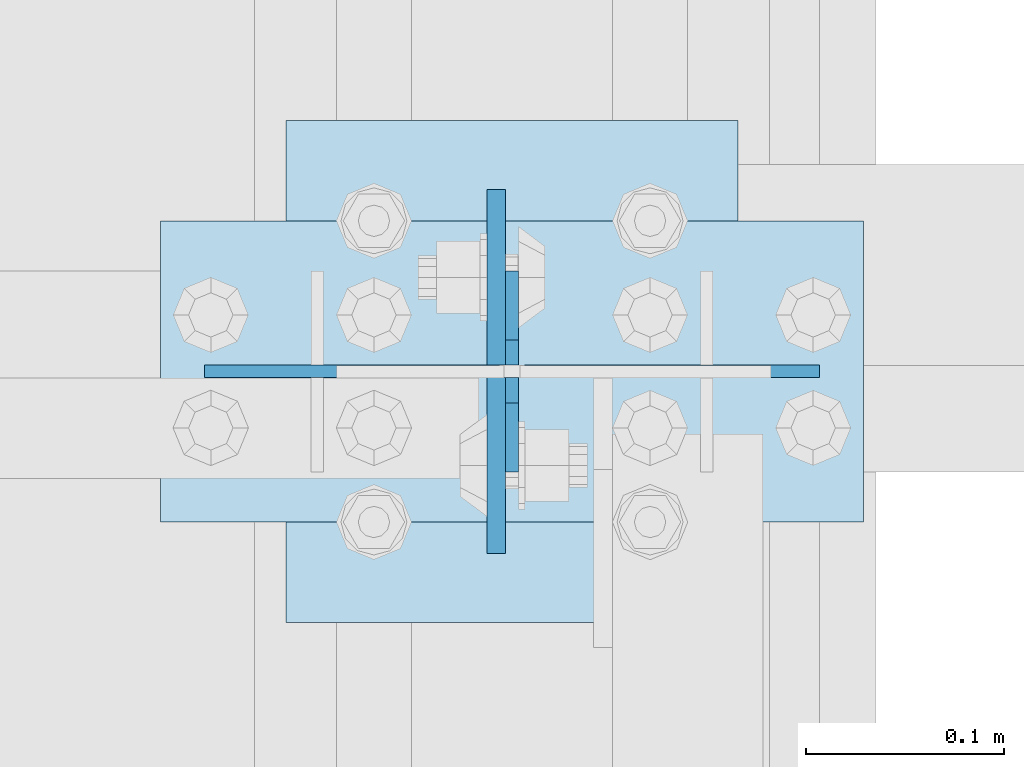
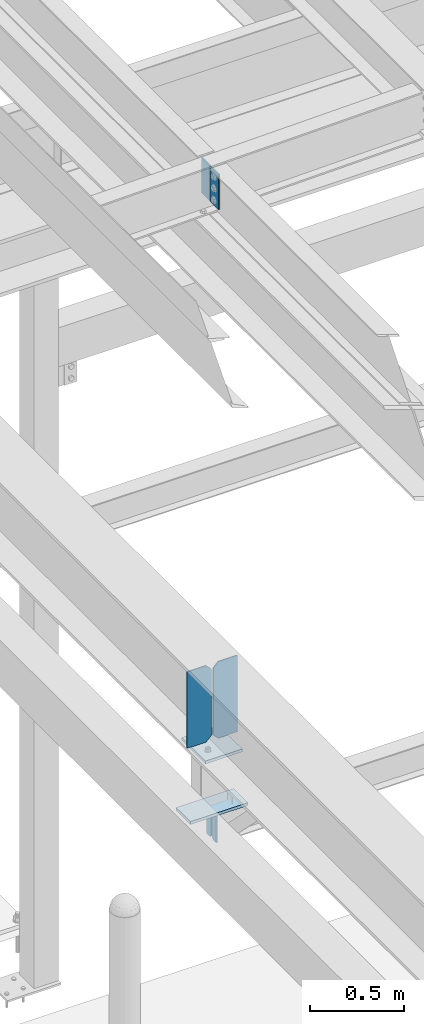
# One storey, part 3387 of 3843: 8 plates, 4 elements without a shape of their own.
"""IFC2X3 building model written with IfcOpenShell, lengths in millimetres."""

from ifc_helpers import new_model, si_unit, frame, origin_with_axes, place, context, subcontext, project, spatial, faceted_brep, material, type_object, element, aggregate, save


model = new_model("IFC2X3")

# Units and contexts
model_context = context("Model", 3, precision=1e-05, world=origin_with_axes())
body_context = subcontext(model_context, "Body", "Model", "MODEL_VIEW")
ifc_project = project(units=[si_unit("LENGTHUNIT", "METRE", prefix="MILLI"), si_unit("AREAUNIT", "SQUARE_METRE"), si_unit("VOLUMEUNIT", "CUBIC_METRE"), si_unit("MASSUNIT", "GRAM", prefix="KILO"), si_unit("TIMEUNIT", "SECOND"), si_unit("PLANEANGLEUNIT", "RADIAN"), si_unit("SOLIDANGLEUNIT", "STERADIAN"), si_unit("THERMODYNAMICTEMPERATUREUNIT", "DEGREE_CELSIUS"), si_unit("LUMINOUSINTENSITYUNIT", "LUMEN")], contexts=[model_context])

# Site, building, storey
site_placement = place(None, origin_with_axes())
site = spatial("IfcSite", under=ifc_project, at=site_placement, CompositionType="ELEMENT")
building_placement = place(site_placement, origin_with_axes())
building = spatial("IfcBuilding", under=site, at=building_placement, Name="Undefined", CompositionType="ELEMENT")
storey_placement = place(building_placement, origin_with_axes())
storey = spatial("IfcBuildingStorey", under=building, at=storey_placement, Name="Undefined", CompositionType="ELEMENT", Elevation=0.0)

# Assembly, plates
assembly_1_placement = place(storey_placement, origin_with_axes())
assembly_1 = element("IfcElementAssembly", 1, at=assembly_1_placement, inside=storey, Name="BEAM", AssemblyPlace="NOTDEFINED", PredefinedType="RIGID_FRAME")
ifc_material = material(Name="STEEL/A572-50")
plate_type_1 = type_object("IfcPlateType", PredefinedType="NOTDEFINED")
plate_1_placement = place(assembly_1_placement, frame((36568.0624999856, 79803.6249999999, 45691.4946293709), z_axis=(0.0, -1.0, 0.0), x_axis=(0.0, 0.0, -1.0)))
plate_1 = element("IfcPlate", 2, at=plate_1_placement, type_object=plate_type_1, material=ifc_material, Name="PLATE", context=body_context, shape_type="Brep", body=[
    faceted_brep([(0.0, -4.76249999999709, 0.0), (0.0, -4.76249999999709, 88.9000015258789), (0.0, 4.76249999999709, 88.9000015258789), (0.0, 4.76249999999709, 0.0), (228.600006102781, -4.7625000004191, 88.9000015257589), (228.600006102781, 4.76249999954598, 88.9000015257443), (228.600006103079, -4.7625000004482, 7.27595761418343e-12), (228.600006103079, 4.76249999954598, -7.27595761418343e-12)], [[[0, 1, 2, 3]], [[1, 4, 5, 2]], [[4, 6, 7, 5]], [[6, 0, 3, 7]], [[5, 7, 3, 2]], [[6, 4, 1, 0]]]),
])
plate_2_placement = place(assembly_1_placement, frame((36568.0624999913, 79809.9749999999, 45691.494629371), z_axis=(0.0, 1.0, 0.0), x_axis=(0.0, 0.0, -1.0)))
plate_2 = element("IfcPlate", 3, at=plate_2_placement, type_object=plate_type_1, material=ifc_material, Name="PLATE", context=body_context, shape_type="Brep", body=[
    faceted_brep([(0.0, -4.76249999999709, 0.0), (0.0, -4.76249999999709, 88.9000015258789), (0.0, 4.76249999999709, 88.9000015258789), (0.0, 4.76249999999709, 0.0), (228.600006102781, -4.7625000004191, 88.9000015257589), (228.600006102781, 4.76249999954598, 88.9000015257443), (228.600006103079, -4.7625000004482, 7.27595761418343e-12), (228.600006103079, 4.76249999954598, -7.27595761418343e-12)], [[[0, 1, 2, 3]], [[1, 4, 5, 2]], [[4, 6, 7, 5]], [[6, 0, 3, 7]], [[5, 7, 3, 2]], [[6, 4, 1, 0]]]),
])
aggregate(assembly_1, [plate_1, plate_2])

assembly_2_placement = place(storey_placement, origin_with_axes())
assembly_2 = element("IfcElementAssembly", 4, at=assembly_2_placement, inside=storey, Name="BEAM", AssemblyPlace="NOTDEFINED", PredefinedType="RIGID_FRAME")
plate_type_2 = type_object("IfcPlateType", PredefinedType="NOTDEFINED")
plate_3_placement = place(assembly_2_placement, frame((36576.0000030517, 79857.6, 41495.6625), z_axis=(0.0, 0.0, -1.0), x_axis=(0.0, -1.0, 0.0)))
plate_3 = element("IfcPlate", 5, at=plate_3_placement, type_object=plate_type_2, material=ifc_material, Name="PLATE", context=body_context, shape_type="Brep", body=[
    faceted_brep([(0.0, -3.17499999999927, 0.0), (0.0, -3.17500000000291, 187.324999999997), (0.0, 3.17500000000291, 187.324999999997), (0.0, 3.17499999999927, 0.0), (34.9250001907349, -3.17500000000291, 187.324999999997), (34.9250001907349, 3.17500000000291, 187.324999999997), (47.625, -3.17500000000291, 174.625000190732), (47.625, 3.17500000000291, 174.625000190732), (47.625, -3.17499999999927, 12.6999998092651), (47.625, 3.17499999999927, 12.6999998092651), (34.9250001907349, -3.17499999999927, 0.0), (34.9250001907349, 3.17499999999927, 0.0)], [[[0, 1, 2, 3]], [[1, 4, 5, 2]], [[4, 6, 7, 5]], [[6, 8, 9, 7]], [[8, 10, 11, 9]], [[10, 0, 3, 11]], [[5, 7, 9, 11, 3, 2]], [[10, 8, 6, 4, 1, 0]]]),
])
plate_4_placement = place(assembly_2_placement, frame((36576.0000030517, 79756.0, 41495.6625), z_axis=(0.0, 0.0, -1.0), x_axis=(0.0, 1.0, 0.0)))
plate_4 = element("IfcPlate", 6, at=plate_4_placement, type_object=plate_type_2, material=ifc_material, Name="PLATE", context=body_context, shape_type="Brep", body=[
    faceted_brep([(0.0, -3.17499999999927, 0.0), (0.0, -3.17500000000291, 187.324999999997), (0.0, 3.17500000000291, 187.324999999997), (0.0, 3.17499999999927, 0.0), (34.9250001907349, -3.17500000000291, 187.324999999997), (34.9250001907349, 3.17500000000291, 187.324999999997), (47.625, -3.17500000000291, 174.625000190732), (47.625, 3.17500000000291, 174.625000190732), (47.625, -3.17499999999927, 12.6999998092651), (47.625, 3.17499999999927, 12.6999998092651), (34.9250001907349, -3.17499999999927, 0.0), (34.9250001907349, 3.17499999999927, 0.0)], [[[0, 1, 2, 3]], [[1, 4, 5, 2]], [[4, 6, 7, 5]], [[6, 8, 9, 7]], [[8, 10, 11, 9]], [[10, 0, 3, 11]], [[5, 7, 9, 11, 3, 2]], [[10, 8, 6, 4, 1, 0]]]),
])
aggregate(assembly_2, [plate_3, plate_4])

# Assembly, plate
assembly_3_placement = place(storey_placement, origin_with_axes())
assembly_3 = element("IfcElementAssembly", 7, at=assembly_3_placement, inside=storey, Name="POST", AssemblyPlace="NOTDEFINED", PredefinedType="RIGID_FRAME")
plate_type_3 = type_object("IfcPlateType", PredefinedType="NOTDEFINED")
plate_5_placement = place(assembly_3_placement, frame((36753.8000030518, 79730.6, 41513.125), z_axis=(-1.0, 0.0, 0.0), x_axis=(0.0, 1.0, 0.0)))
plate_5 = element("IfcPlate", 8, at=plate_5_placement, type_object=plate_type_3, material=ifc_material, Name="PLATE", context=body_context, shape_type="Brep", body=[
    faceted_brep([(0.0, -9.52500000000146, 0.0), (0.0, -9.52500000000146, 355.599999999999), (0.0, 9.52500000000146, 355.599999999999), (0.0, 9.52500000000146, 0.0), (152.399999999994, -9.52500000000146, 355.599999999999), (152.399999999994, 9.52500000000146, 355.599999999999), (152.400000000001, -9.52500000000146, 0.0), (152.400000000001, 9.52500000000146, 0.0)], [[[0, 1, 2, 3]], [[1, 4, 5, 2]], [[4, 6, 7, 5]], [[6, 0, 3, 7]], [[5, 7, 3, 2]], [[6, 4, 1, 0]]]),
])

# Assembly, plates
assembly_4_placement = place(storey_placement, origin_with_axes())
assembly_4 = element("IfcElementAssembly", 9, at=assembly_4_placement, inside=storey, Name="BEAM", AssemblyPlace="NOTDEFINED", PredefinedType="RIGID_FRAME")
plate_type_4 = type_object("IfcPlateType", PredefinedType="NOTDEFINED")
plate_6_placement = place(assembly_4_placement, frame((36731.575, 79806.8, 42446.575), z_axis=(0.0, 0.0, -1.0), x_axis=(-1.0, 0.0, 0.0)))
plate_6 = element("IfcPlate", 10, at=plate_6_placement, type_object=plate_type_4, material=ifc_material, Name="PLATE", context=body_context, shape_type="Brep", body=[
    faceted_brep([(0.0, -3.17499999999927, 0.0), (0.0, -3.17500000000291, 498.475000000006), (0.0, 3.17500000000291, 498.475000000006), (0.0, 3.17499999999927, 0.0), (117.475000000006, -3.17500000000291, 498.475000000006), (117.475000000006, 3.17500000000291, 498.475000000006), (149.225000000006, -3.17500000000291, 466.725000000006), (149.225000000006, 3.17500000000291, 466.725000000006), (149.225000000006, -3.17500000000291, 31.75), (149.225000000006, 3.17500000000291, 31.75), (117.475000000006, -3.17500000000291, 0.0), (117.475000000006, 3.17500000000291, 0.0)], [[[0, 1, 2, 3]], [[1, 4, 5, 2]], [[4, 6, 7, 5]], [[6, 8, 9, 7]], [[8, 10, 11, 9]], [[10, 0, 3, 11]], [[5, 7, 9, 11, 3, 2]], [[10, 8, 6, 4, 1, 0]]]),
])
plate_7_placement = place(assembly_4_placement, frame((36420.425, 79806.8, 42446.575), z_axis=(0.0, 0.0, -1.0), x_axis=(1.0, 0.0, 0.0)))
plate_7 = element("IfcPlate", 11, at=plate_7_placement, type_object=plate_type_4, material=ifc_material, Name="PLATE", context=body_context, shape_type="Brep", body=[
    faceted_brep([(0.0, -3.17499999999927, 0.0), (0.0, -3.17500000000291, 498.475000000006), (0.0, 3.17500000000291, 498.475000000006), (0.0, 3.17499999999927, 0.0), (117.475000000006, -3.17500000000291, 498.475000000006), (117.475000000006, 3.17500000000291, 498.475000000006), (149.225000000006, -3.17500000000291, 466.725000000006), (149.225000000006, 3.17500000000291, 466.725000000006), (149.225000000006, -3.17500000000291, 31.75), (149.225000000006, 3.17500000000291, 31.75), (117.475000000006, -3.17500000000291, 0.0), (117.475000000006, 3.17500000000291, 0.0)], [[[0, 1, 2, 3]], [[1, 4, 5, 2]], [[4, 6, 7, 5]], [[6, 8, 9, 7]], [[8, 10, 11, 9]], [[10, 0, 3, 11]], [[5, 7, 9, 11, 3, 2]], [[10, 8, 6, 4, 1, 0]]]),
])
aggregate(assembly_4, [plate_6, plate_7])

# Plate
plate_type_5 = type_object("IfcPlateType", PredefinedType="NOTDEFINED")
plate_8_placement = place(assembly_3_placement, frame((36461.7000005181, 79933.8, 41916.35), z_axis=(0.0, -1.0, 0.0), x_axis=(1.0, 0.0, 0.0)))
plate_8 = element("IfcPlate", 12, at=plate_8_placement, type_object=plate_type_5, material=ifc_material, Name="PLATE", context=body_context, shape_type="Brep", body=[
    faceted_brep([(0.0, -9.52500000000146, 0.0), (0.0, -9.52500000000146, 254.0), (0.0, 9.52500000000146, 254.0), (0.0, 9.52500000000146, 0.0), (228.599999999999, -9.52500000000146, 254.0), (228.599999999999, 9.52500000000146, 254.0), (228.599999999999, -9.52500000000146, 0.0), (228.599999999999, 9.52500000000146, 0.0)], [[[0, 1, 2, 3]], [[1, 4, 5, 2]], [[4, 6, 7, 5]], [[6, 0, 3, 7]], [[5, 7, 3, 2]], [[6, 4, 1, 0]]]),
])

aggregate(assembly_3, [plate_8, plate_5])

save(model, "model.ifc")
